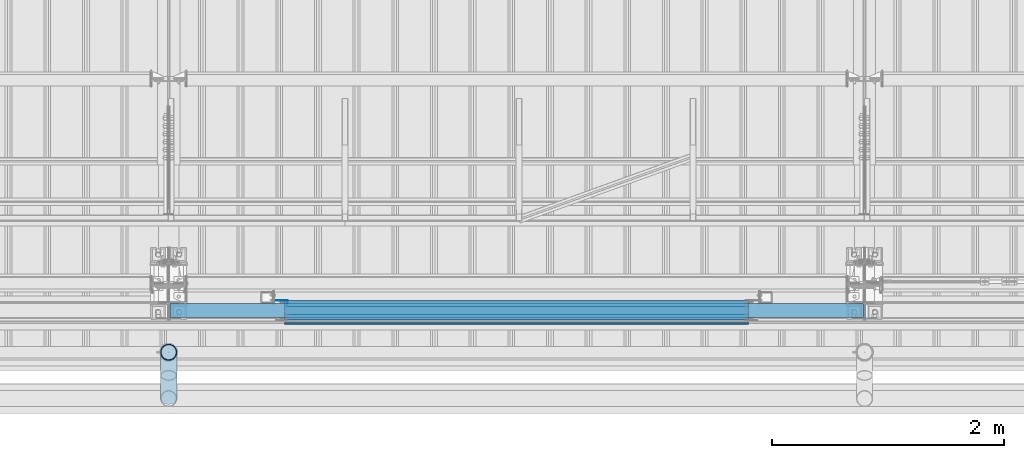
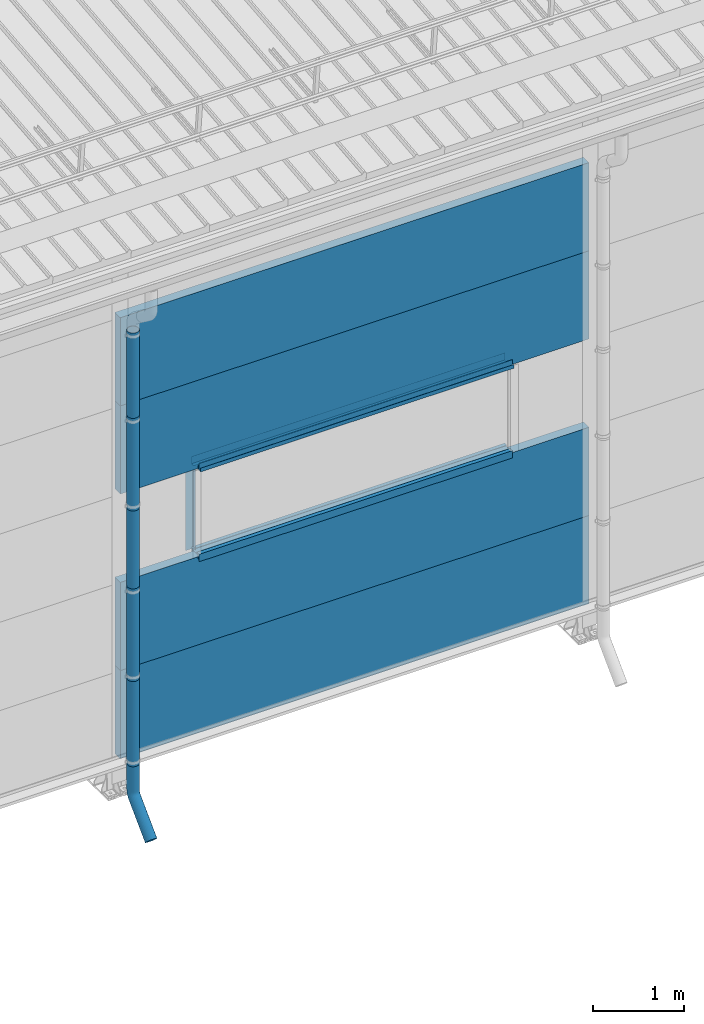
# One storey, part 41 of 709: 18 beams, 18 elements without a shape of their own.
"""IFC4 building model written with IfcOpenShell, lengths in millimetres."""

from ifc_helpers import new_model, entity, si_unit, direction, frame, origin_with_axes, place, context, subcontext, project, spatial, line, indexed_curve, outline, extrude, material, element, aggregate, save


model = new_model("IFC4")

# Units and contexts
model_context = context("Model", 3, precision=0.2, world=origin_with_axes(), true_north=direction((0.0, 1.0)))
body_context = subcontext(model_context, "Body", "Model", "MODEL_VIEW")
ifc_project = project(units=[si_unit("LENGTHUNIT", "METRE", prefix="MILLI"), si_unit("AREAUNIT", "SQUARE_METRE"), si_unit("VOLUMEUNIT", "CUBIC_METRE"), si_unit("MASSUNIT", "GRAM", prefix="KILO"), si_unit("TIMEUNIT", "SECOND"), si_unit("PLANEANGLEUNIT", "RADIAN"), si_unit("SOLIDANGLEUNIT", "STERADIAN"), si_unit("THERMODYNAMICTEMPERATUREUNIT", "DEGREE_CELSIUS"), si_unit("LUMINOUSINTENSITYUNIT", "LUMEN")], contexts=[model_context])

# Site, building, storey
site_placement = place(None, origin_with_axes())
site = spatial("IfcSite", under=ifc_project, at=site_placement, CompositionType="ELEMENT")
building_placement = place(site_placement, origin_with_axes())
building = spatial("IfcBuilding", under=site, at=building_placement, Name="Undefined", CompositionType="ELEMENT")
storey_placement = place(building_placement, origin_with_axes())
storey = spatial("IfcBuildingStorey", under=building, at=storey_placement, Name="Undefined", CompositionType="ELEMENT", Elevation=0.0)

# Assembly, beam
assembly_1_placement = place(storey_placement, frame((16010.0, -60.0, 895.0), z_axis=(0.0, 0.0, -1.0), x_axis=(1.0, 0.0, 0.0)))
assembly_1 = element("IfcElementAssembly", 1, at=assembly_1_placement, inside=storey)
ifc_material_1 = material(Name="Insulation", Category="Insulation")
beam_1_placement = place(assembly_1_placement, origin_with_axes())
beam_1 = element("IfcBeam", 2, at=beam_1_placement, material=ifc_material_1, ObjectType="P-107", context=body_context, shape_type="SolidModel", body=[
    extrude(outline(indexed_curve([(-595.0, -60.0), (595.0, -60.0), (595.0, 60.0), (-595.0, 60.0)], segments=[line(1, 2, 3, 4, 1)])), frame((0.0, 0.0, 0.0), z_axis=(-1.0, 0.0, 0.0), x_axis=(0.0, 0.0, 1.0)), (0.0, 0.0, -1.0), 5980.0),
])
aggregate(assembly_1, [beam_1])

assembly_2_placement = place(storey_placement, frame((16010.0, -60.0, 2085.0), z_axis=(0.0, 0.0, -1.0), x_axis=(1.0, 0.0, 0.0)))
assembly_2 = element("IfcElementAssembly", 3, at=assembly_2_placement, inside=storey)
beam_2_placement = place(assembly_2_placement, origin_with_axes())
beam_2 = element("IfcBeam", 4, at=beam_2_placement, material=ifc_material_1, ObjectType="P-107", context=body_context, shape_type="SolidModel", body=[
    extrude(outline(indexed_curve([(-595.0, -60.0), (595.0, -60.0), (595.0, 60.0), (-595.0, 60.0)], segments=[line(1, 2, 3, 4, 1)])), frame((0.0, 0.0, 0.0), z_axis=(-1.0, 0.0, 0.0), x_axis=(0.0, 0.0, 1.0)), (0.0, 0.0, -1.0), 5980.0),
])
aggregate(assembly_2, [beam_2])

assembly_3_placement = place(storey_placement, frame((16010.0, -60.0, 4465.0), z_axis=(0.0, 0.0, -1.0), x_axis=(1.0, 0.0, 0.0)))
assembly_3 = element("IfcElementAssembly", 5, at=assembly_3_placement, inside=storey)
beam_3_placement = place(assembly_3_placement, origin_with_axes())
beam_3 = element("IfcBeam", 6, at=beam_3_placement, material=ifc_material_1, ObjectType="P-107", context=body_context, shape_type="SolidModel", body=[
    extrude(outline(indexed_curve([(-595.0, -60.0), (595.0, -60.0), (595.0, 60.0), (-595.0, 60.0)], segments=[line(1, 2, 3, 4, 1)])), frame((0.0, 0.0, 0.0), z_axis=(-1.0, 0.0, 0.0), x_axis=(0.0, 0.0, 1.0)), (0.0, 0.0, -1.0), 5980.0),
])
aggregate(assembly_3, [beam_3])

assembly_4_placement = place(storey_placement, frame((16010.0, -60.0, 5655.0), z_axis=(0.0, 0.0, -1.0), x_axis=(1.0, 0.0, 0.0)))
assembly_4 = element("IfcElementAssembly", 7, at=assembly_4_placement, inside=storey)
beam_4_placement = place(assembly_4_placement, origin_with_axes())
beam_4 = element("IfcBeam", 8, at=beam_4_placement, material=ifc_material_1, ObjectType="P-107", context=body_context, shape_type="SolidModel", body=[
    extrude(outline(indexed_curve([(-595.0, -60.0), (595.0, -60.0), (595.0, 60.0), (-595.0, 60.0)], segments=[line(1, 2, 3, 4, 1)])), frame((0.0, 0.0, 0.0), z_axis=(-1.0, 0.0, 0.0), x_axis=(0.0, 0.0, 1.0)), (0.0, 0.0, -1.0), 5980.0),
])
aggregate(assembly_4, [beam_4])

assembly_5_placement = place(storey_placement, frame((17000.0, 1.0, 2725.0), z_axis=(0.0, 1.0, 0.0), x_axis=(1.0, 0.0, 0.0)))
assembly_5 = element("IfcElementAssembly", 9, at=assembly_5_placement, inside=storey)
ifc_material_2 = material(Name="Steel_Undefined", Category="STEEL")
beam_5_placement = place(assembly_5_placement, origin_with_axes())
beam_5 = element("IfcBeam", 10, at=beam_5_placement, material=ifc_material_2, context=body_context, shape_type="SolidModel", body=[
    extrude(outline(indexed_curve([(-25.0, -1.0), (25.0, -1.0), (25.0, 99.0), (23.0, 99.0), (23.0, 1.0), (-25.0, 1.0)], segments=[line(1, 2, 3, 4, 5, 6, 1)])), frame((0.0, 0.0, 0.0), z_axis=(-1.0, 0.0, 0.0), x_axis=(0.0, 0.0, 1.0)), (0.0, 0.0, -1.0), 4000.0),
])
aggregate(assembly_5, [beam_5])

assembly_6_placement = place(storey_placement, frame((21000.0, -60.0, 2680.0), z_axis=(0.0, 1.0, 0.0), x_axis=(-1.0, 0.0, 0.0)))
assembly_6 = element("IfcElementAssembly", 11, at=assembly_6_placement, inside=storey)
beam_6_placement = place(assembly_6_placement, origin_with_axes())
beam_6 = element("IfcBeam", 12, at=beam_6_placement, material=ifc_material_2, context=body_context, shape_type="SolidModel", body=[
    extrude(outline(indexed_curve([(-70.0, -25.0), (-68.0, -25.0), (-68.0, 23.0), (68.0, 23.0), (68.0, -25.0), (70.0, -25.0), (70.0, 25.0), (-70.0, 25.0)], segments=[line(1, 2, 3, 4, 5, 6, 7, 8, 1)])), frame((0.0, 0.0, 0.0), z_axis=(-1.0, 0.0, 0.0), x_axis=(0.0, 0.0, 1.0)), (0.0, 0.0, -1.0), 4000.0),
])
aggregate(assembly_6, [beam_6])

assembly_7_placement = place(storey_placement, frame((21000.0, -119.0, 2725.0), z_axis=(0.0, -1.0, 0.0), x_axis=(-1.0, 0.0, 0.0)))
assembly_7 = element("IfcElementAssembly", 13, at=assembly_7_placement, inside=storey)
beam_7_placement = place(assembly_7_placement, origin_with_axes())
beam_7 = element("IfcBeam", 14, at=beam_7_placement, material=ifc_material_2, context=body_context, shape_type="SolidModel", body=[
    extrude(outline(indexed_curve([(-25.0, -1.0), (25.0, -1.0), (25.0, 99.0), (23.0, 99.0), (23.0, 1.0), (-25.0, 1.0)], segments=[line(1, 2, 3, 4, 5, 6, 1)])), frame((0.0, 0.0, 0.0), z_axis=(-1.0, 0.0, 0.0), x_axis=(0.0, 0.0, 1.0)), (0.0, 0.0, -1.0), 4000.0),
])
aggregate(assembly_7, [beam_7])

assembly_8_placement = place(storey_placement, frame((21000.0, 1.0, 3845.0), z_axis=(0.0, 1.0, 0.0), x_axis=(-1.0, 0.0, 0.0)))
assembly_8 = element("IfcElementAssembly", 15, at=assembly_8_placement, inside=storey)
beam_8_placement = place(assembly_8_placement, origin_with_axes())
beam_8 = element("IfcBeam", 16, at=beam_8_placement, material=ifc_material_2, context=body_context, shape_type="SolidModel", body=[
    extrude(outline(indexed_curve([(-25.0, -1.0), (25.0, -1.0), (25.0, 99.0), (23.0, 99.0), (23.0, 1.0), (-25.0, 1.0)], segments=[line(1, 2, 3, 4, 5, 6, 1)])), frame((0.0, 0.0, 0.0), z_axis=(-1.0, 0.0, 0.0), x_axis=(0.0, 0.0, 1.0)), (0.0, 0.0, -1.0), 4000.0),
])
aggregate(assembly_8, [beam_8])

assembly_9_placement = place(storey_placement, frame((17000.0, -60.0, 3890.0), z_axis=(0.0, 1.0, 0.0), x_axis=(1.0, 0.0, 0.0)))
assembly_9 = element("IfcElementAssembly", 17, at=assembly_9_placement, inside=storey)
beam_9_placement = place(assembly_9_placement, origin_with_axes())
beam_9 = element("IfcBeam", 18, at=beam_9_placement, material=ifc_material_2, context=body_context, shape_type="SolidModel", body=[
    extrude(outline(indexed_curve([(-70.0, -25.0), (-68.0, -25.0), (-68.0, 23.0), (68.0, 23.0), (68.0, -25.0), (70.0, -25.0), (70.0, 25.0), (-70.0, 25.0)], segments=[line(1, 2, 3, 4, 5, 6, 7, 8, 1)])), frame((0.0, 0.0, 0.0), z_axis=(-1.0, 0.0, 0.0), x_axis=(0.0, 0.0, 1.0)), (0.0, 0.0, -1.0), 4000.0),
])
aggregate(assembly_9, [beam_9])

assembly_10_placement = place(storey_placement, frame((17000.0, -119.0, 3855.0), z_axis=(0.0, -1.0, 0.0), x_axis=(1.0, 0.0, 0.0)))
assembly_10 = element("IfcElementAssembly", 19, at=assembly_10_placement, inside=storey)
beam_10_placement = place(assembly_10_placement, origin_with_axes())
beam_10 = element("IfcBeam", 20, at=beam_10_placement, material=ifc_material_2, context=body_context, shape_type="SolidModel", body=[
    extrude(outline(indexed_curve([(-25.0, -1.0), (25.0, -1.0), (25.0, 99.0), (23.0, 99.0), (23.0, 1.0), (-25.0, 1.0)], segments=[line(1, 2, 3, 4, 5, 6, 1)])), frame((0.0, 0.0, 0.0), z_axis=(-1.0, 0.0, 0.0), x_axis=(0.0, 0.0, 1.0)), (0.0, 0.0, -1.0), 4000.0),
])
aggregate(assembly_10, [beam_10])

assembly_11_placement = place(storey_placement, frame((17000.0, -169.0, 3860.0), z_axis=(0.0, -1.0, 0.0), x_axis=(1.0, 0.0, 0.0)))
assembly_11 = element("IfcElementAssembly", 21, at=assembly_11_placement, inside=storey)
beam_11_placement = place(assembly_11_placement, origin_with_axes())
beam_11 = element("IfcBeam", 22, at=beam_11_placement, material=ifc_material_2, context=body_context, shape_type="SolidModel", body=[
    extrude(outline(indexed_curve([(-10.0, -1.0), (10.0, -1.0), (10.0, 49.0), (8.0, 49.0), (8.0, 1.0), (-10.0, 1.0)], segments=[line(1, 2, 3, 4, 5, 6, 1)])), frame((0.0, 0.0, 0.0), z_axis=(-1.0, 0.0, 0.0), x_axis=(0.0, 0.0, 1.0)), (0.0, 0.0, -1.0), 4000.0),
])
aggregate(assembly_11, [beam_11])

assembly_12_placement = place(storey_placement, frame((17025.0, 1.0, 3870.0), z_axis=(0.0, 1.0, 0.0), x_axis=(0.0, 0.0, -1.0)))
assembly_12 = element("IfcElementAssembly", 23, at=assembly_12_placement, inside=storey)
beam_12_placement = place(assembly_12_placement, origin_with_axes())
beam_12 = element("IfcBeam", 24, at=beam_12_placement, material=ifc_material_2, context=body_context, shape_type="SolidModel", body=[
    extrude(outline(indexed_curve([(-25.0, -1.0), (25.0, -1.0), (25.0, 99.0), (23.0, 99.0), (23.0, 1.0), (-25.0, 1.0)], segments=[line(1, 2, 3, 4, 5, 6, 1)])), frame((0.0, 0.0, 0.0), z_axis=(-1.0, 0.0, 0.0), x_axis=(0.0, 0.0, 1.0)), (0.0, 0.0, -1.0), 1170.0),
])
aggregate(assembly_12, [beam_12])

assembly_13_placement = place(storey_placement, frame((16000.0, -420.0, 6276.92297), z_axis=(0.0, 1.0, 0.0), x_axis=(0.0, 0.0, -1.0)))
assembly_13 = element("IfcElementAssembly", 25, at=assembly_13_placement, inside=storey)
beam_13_placement = place(assembly_13_placement, origin_with_axes())
beam_13 = element("IfcBeam", 26, at=beam_13_placement, material=ifc_material_2, ObjectType="614", context=body_context, shape_type="SolidModel", body=[
    extrude(outline(indexed_curve([(70.0, 0.0), (69.61653, 7.31699), (68.47033, 14.55382), (66.57396, 21.63119), (63.94818, 28.47157), (60.62178, 35.0), (56.63119, 41.14497), (52.02014, 46.83914), (46.83914, 52.02014), (41.14497, 56.63119), (35.0, 60.62178), (28.47157, 63.94818), (21.63119, 66.57396), (14.55382, 68.47033), (7.31699, 69.61653), (0.0, 70.0), (-7.31699, 69.61653), (-14.55382, 68.47033), (-21.63119, 66.57396), (-28.47157, 63.94818), (-35.0, 60.62178), (-41.14497, 56.63119), (-46.83914, 52.02014), (-52.02014, 46.83914), (-56.63119, 41.14497), (-60.62178, 35.0), (-63.94818, 28.47157), (-66.57396, 21.63119), (-68.47033, 14.55382), (-69.61653, 7.31699), (-70.0, 0.0), (-69.61653, -7.31699), (-68.47033, -14.55382), (-66.57396, -21.63119), (-63.94818, -28.47157), (-60.62178, -35.0), (-56.63119, -41.14497), (-52.02014, -46.83914), (-46.83914, -52.02014), (-41.14497, -56.63119), (-35.0, -60.62178), (-28.47157, -63.94818), (-21.63119, -66.57396), (-14.55382, -68.47033), (-7.31699, -69.61653), (0.0, -70.0), (7.31699, -69.61653), (14.55382, -68.47033), (21.63119, -66.57396), (28.47157, -63.94818), (35.0, -60.62178), (41.14497, -56.63119), (46.83914, -52.02014), (52.02014, -46.83914), (56.63119, -41.14497), (60.62178, -35.0), (63.94818, -28.47157), (66.57396, -21.63119), (68.47033, -14.55382), (69.61653, -7.31699)], segments=[line(1, 2, 3, 4, 5, 6, 7, 8, 9, 10, 11, 12, 13, 14, 15, 16, 17, 18, 19, 20, 21, 22, 23, 24, 25, 26, 27, 28, 29, 30, 31, 32, 33, 34, 35, 36, 37, 38, 39, 40, 41, 42, 43, 44, 45, 46, 47, 48, 49, 50, 51, 52, 53, 54, 55, 56, 57, 58, 59, 60, 1)]), holes=[indexed_curve([(65.0, 0.0), (64.64392, -6.79435), (63.57959, -13.51426), (61.81867, -20.0861), (59.38045, -26.43788), (56.29165, -32.5), (52.5861, -38.20604), (48.30441, -43.49349), (43.49349, -48.30441), (38.20604, -52.5861), (32.5, -56.29165), (26.43788, -59.38045), (20.0861, -61.81867), (13.51426, -63.57959), (6.79435, -64.64392), (0.0, -65.0), (-6.79435, -64.64392), (-13.51426, -63.57959), (-20.0861, -61.81867), (-26.43788, -59.38045), (-32.5, -56.29165), (-38.20604, -52.5861), (-43.49349, -48.30441), (-48.30441, -43.49349), (-52.5861, -38.20604), (-56.29165, -32.5), (-59.38045, -26.43788), (-61.81867, -20.0861), (-63.57959, -13.51426), (-64.64392, -6.79435), (-65.0, 0.0), (-64.64392, 6.79435), (-63.57959, 13.51426), (-61.81867, 20.0861), (-59.38045, 26.43788), (-56.29165, 32.5), (-52.5861, 38.20604), (-48.30441, 43.49349), (-43.49349, 48.30441), (-38.20604, 52.5861), (-32.5, 56.29165), (-26.43788, 59.38045), (-20.0861, 61.81867), (-13.51426, 63.57959), (-6.79435, 64.64392), (0.0, 65.0), (6.79435, 64.64392), (13.51426, 63.57959), (20.0861, 61.81867), (26.43788, 59.38045), (32.5, 56.29165), (38.20604, 52.5861), (43.49349, 48.30441), (48.30441, 43.49349), (52.5861, 38.20604), (56.29165, 32.5), (59.38045, 26.43788), (61.81867, 20.0861), (63.57959, 13.51426), (64.64392, 6.79435)], segments=[line(1, 2, 3, 4, 5, 6, 7, 8, 9, 10, 11, 12, 13, 14, 15, 16, 17, 18, 19, 20, 21, 22, 23, 24, 25, 26, 27, 28, 29, 30, 31, 32, 33, 34, 35, 36, 37, 38, 39, 40, 41, 42, 43, 44, 45, 46, 47, 48, 49, 50, 51, 52, 53, 54, 55, 56, 57, 58, 59, 60, 1)])]), frame((0.0, 0.0, 0.0), z_axis=(-1.0, 0.0, 0.0), x_axis=(0.0, 0.0, 1.0)), (0.0, 0.0, -1.0), 1250.0),
])
aggregate(assembly_13, [beam_13])

assembly_14_placement = place(storey_placement, frame((16000.0, -420.0, 5126.92297), z_axis=(0.0, 1.0, 0.0), x_axis=(0.0, 0.0, -1.0)))
assembly_14 = element("IfcElementAssembly", 27, at=assembly_14_placement, inside=storey)
beam_14_placement = place(assembly_14_placement, origin_with_axes())
beam_14 = element("IfcBeam", 28, at=beam_14_placement, material=ifc_material_2, ObjectType="614", context=body_context, shape_type="SolidModel", body=[
    extrude(outline(indexed_curve([(70.0, 0.0), (69.61653, 7.31699), (68.47033, 14.55382), (66.57396, 21.63119), (63.94818, 28.47157), (60.62178, 35.0), (56.63119, 41.14497), (52.02014, 46.83914), (46.83914, 52.02014), (41.14497, 56.63119), (35.0, 60.62178), (28.47157, 63.94818), (21.63119, 66.57396), (14.55382, 68.47033), (7.31699, 69.61653), (0.0, 70.0), (-7.31699, 69.61653), (-14.55382, 68.47033), (-21.63119, 66.57396), (-28.47157, 63.94818), (-35.0, 60.62178), (-41.14497, 56.63119), (-46.83914, 52.02014), (-52.02014, 46.83914), (-56.63119, 41.14497), (-60.62178, 35.0), (-63.94818, 28.47157), (-66.57396, 21.63119), (-68.47033, 14.55382), (-69.61653, 7.31699), (-70.0, 0.0), (-69.61653, -7.31699), (-68.47033, -14.55382), (-66.57396, -21.63119), (-63.94818, -28.47157), (-60.62178, -35.0), (-56.63119, -41.14497), (-52.02014, -46.83914), (-46.83914, -52.02014), (-41.14497, -56.63119), (-35.0, -60.62178), (-28.47157, -63.94818), (-21.63119, -66.57396), (-14.55382, -68.47033), (-7.31699, -69.61653), (0.0, -70.0), (7.31699, -69.61653), (14.55382, -68.47033), (21.63119, -66.57396), (28.47157, -63.94818), (35.0, -60.62178), (41.14497, -56.63119), (46.83914, -52.02014), (52.02014, -46.83914), (56.63119, -41.14497), (60.62178, -35.0), (63.94818, -28.47157), (66.57396, -21.63119), (68.47033, -14.55382), (69.61653, -7.31699)], segments=[line(1, 2, 3, 4, 5, 6, 7, 8, 9, 10, 11, 12, 13, 14, 15, 16, 17, 18, 19, 20, 21, 22, 23, 24, 25, 26, 27, 28, 29, 30, 31, 32, 33, 34, 35, 36, 37, 38, 39, 40, 41, 42, 43, 44, 45, 46, 47, 48, 49, 50, 51, 52, 53, 54, 55, 56, 57, 58, 59, 60, 1)]), holes=[indexed_curve([(65.0, 0.0), (64.64392, -6.79435), (63.57959, -13.51426), (61.81867, -20.0861), (59.38045, -26.43788), (56.29165, -32.5), (52.5861, -38.20604), (48.30441, -43.49349), (43.49349, -48.30441), (38.20604, -52.5861), (32.5, -56.29165), (26.43788, -59.38045), (20.0861, -61.81867), (13.51426, -63.57959), (6.79435, -64.64392), (0.0, -65.0), (-6.79435, -64.64392), (-13.51426, -63.57959), (-20.0861, -61.81867), (-26.43788, -59.38045), (-32.5, -56.29165), (-38.20604, -52.5861), (-43.49349, -48.30441), (-48.30441, -43.49349), (-52.5861, -38.20604), (-56.29165, -32.5), (-59.38045, -26.43788), (-61.81867, -20.0861), (-63.57959, -13.51426), (-64.64392, -6.79435), (-65.0, 0.0), (-64.64392, 6.79435), (-63.57959, 13.51426), (-61.81867, 20.0861), (-59.38045, 26.43788), (-56.29165, 32.5), (-52.5861, 38.20604), (-48.30441, 43.49349), (-43.49349, 48.30441), (-38.20604, 52.5861), (-32.5, 56.29165), (-26.43788, 59.38045), (-20.0861, 61.81867), (-13.51426, 63.57959), (-6.79435, 64.64392), (0.0, 65.0), (6.79435, 64.64392), (13.51426, 63.57959), (20.0861, 61.81867), (26.43788, 59.38045), (32.5, 56.29165), (38.20604, 52.5861), (43.49349, 48.30441), (48.30441, 43.49349), (52.5861, 38.20604), (56.29165, 32.5), (59.38045, 26.43788), (61.81867, 20.0861), (63.57959, 13.51426), (64.64392, 6.79435)], segments=[line(1, 2, 3, 4, 5, 6, 7, 8, 9, 10, 11, 12, 13, 14, 15, 16, 17, 18, 19, 20, 21, 22, 23, 24, 25, 26, 27, 28, 29, 30, 31, 32, 33, 34, 35, 36, 37, 38, 39, 40, 41, 42, 43, 44, 45, 46, 47, 48, 49, 50, 51, 52, 53, 54, 55, 56, 57, 58, 59, 60, 1)])]), frame((0.0, 0.0, 0.0), z_axis=(-1.0, 0.0, 0.0), x_axis=(0.0, 0.0, 1.0)), (0.0, 0.0, -1.0), 1250.0),
])
aggregate(assembly_14, [beam_14])

assembly_15_placement = place(storey_placement, frame((16000.0, -420.0, 3976.92297), z_axis=(0.0, 1.0, 0.0), x_axis=(0.0, 0.0, -1.0)))
assembly_15 = element("IfcElementAssembly", 29, at=assembly_15_placement, inside=storey)
beam_15_placement = place(assembly_15_placement, origin_with_axes())
beam_15 = element("IfcBeam", 30, at=beam_15_placement, material=ifc_material_2, ObjectType="614", context=body_context, shape_type="SolidModel", body=[
    extrude(outline(indexed_curve([(70.0, 0.0), (69.61653, 7.31699), (68.47033, 14.55382), (66.57396, 21.63119), (63.94818, 28.47157), (60.62178, 35.0), (56.63119, 41.14497), (52.02014, 46.83914), (46.83914, 52.02014), (41.14497, 56.63119), (35.0, 60.62178), (28.47157, 63.94818), (21.63119, 66.57396), (14.55382, 68.47033), (7.31699, 69.61653), (0.0, 70.0), (-7.31699, 69.61653), (-14.55382, 68.47033), (-21.63119, 66.57396), (-28.47157, 63.94818), (-35.0, 60.62178), (-41.14497, 56.63119), (-46.83914, 52.02014), (-52.02014, 46.83914), (-56.63119, 41.14497), (-60.62178, 35.0), (-63.94818, 28.47157), (-66.57396, 21.63119), (-68.47033, 14.55382), (-69.61653, 7.31699), (-70.0, 0.0), (-69.61653, -7.31699), (-68.47033, -14.55382), (-66.57396, -21.63119), (-63.94818, -28.47157), (-60.62178, -35.0), (-56.63119, -41.14497), (-52.02014, -46.83914), (-46.83914, -52.02014), (-41.14497, -56.63119), (-35.0, -60.62178), (-28.47157, -63.94818), (-21.63119, -66.57396), (-14.55382, -68.47033), (-7.31699, -69.61653), (0.0, -70.0), (7.31699, -69.61653), (14.55382, -68.47033), (21.63119, -66.57396), (28.47157, -63.94818), (35.0, -60.62178), (41.14497, -56.63119), (46.83914, -52.02014), (52.02014, -46.83914), (56.63119, -41.14497), (60.62178, -35.0), (63.94818, -28.47157), (66.57396, -21.63119), (68.47033, -14.55382), (69.61653, -7.31699)], segments=[line(1, 2, 3, 4, 5, 6, 7, 8, 9, 10, 11, 12, 13, 14, 15, 16, 17, 18, 19, 20, 21, 22, 23, 24, 25, 26, 27, 28, 29, 30, 31, 32, 33, 34, 35, 36, 37, 38, 39, 40, 41, 42, 43, 44, 45, 46, 47, 48, 49, 50, 51, 52, 53, 54, 55, 56, 57, 58, 59, 60, 1)]), holes=[indexed_curve([(65.0, 0.0), (64.64392, -6.79435), (63.57959, -13.51426), (61.81867, -20.0861), (59.38045, -26.43788), (56.29165, -32.5), (52.5861, -38.20604), (48.30441, -43.49349), (43.49349, -48.30441), (38.20604, -52.5861), (32.5, -56.29165), (26.43788, -59.38045), (20.0861, -61.81867), (13.51426, -63.57959), (6.79435, -64.64392), (0.0, -65.0), (-6.79435, -64.64392), (-13.51426, -63.57959), (-20.0861, -61.81867), (-26.43788, -59.38045), (-32.5, -56.29165), (-38.20604, -52.5861), (-43.49349, -48.30441), (-48.30441, -43.49349), (-52.5861, -38.20604), (-56.29165, -32.5), (-59.38045, -26.43788), (-61.81867, -20.0861), (-63.57959, -13.51426), (-64.64392, -6.79435), (-65.0, 0.0), (-64.64392, 6.79435), (-63.57959, 13.51426), (-61.81867, 20.0861), (-59.38045, 26.43788), (-56.29165, 32.5), (-52.5861, 38.20604), (-48.30441, 43.49349), (-43.49349, 48.30441), (-38.20604, 52.5861), (-32.5, 56.29165), (-26.43788, 59.38045), (-20.0861, 61.81867), (-13.51426, 63.57959), (-6.79435, 64.64392), (0.0, 65.0), (6.79435, 64.64392), (13.51426, 63.57959), (20.0861, 61.81867), (26.43788, 59.38045), (32.5, 56.29165), (38.20604, 52.5861), (43.49349, 48.30441), (48.30441, 43.49349), (52.5861, 38.20604), (56.29165, 32.5), (59.38045, 26.43788), (61.81867, 20.0861), (63.57959, 13.51426), (64.64392, 6.79435)], segments=[line(1, 2, 3, 4, 5, 6, 7, 8, 9, 10, 11, 12, 13, 14, 15, 16, 17, 18, 19, 20, 21, 22, 23, 24, 25, 26, 27, 28, 29, 30, 31, 32, 33, 34, 35, 36, 37, 38, 39, 40, 41, 42, 43, 44, 45, 46, 47, 48, 49, 50, 51, 52, 53, 54, 55, 56, 57, 58, 59, 60, 1)])]), frame((0.0, 0.0, 0.0), z_axis=(-1.0, 0.0, 0.0), x_axis=(0.0, 0.0, 1.0)), (0.0, 0.0, -1.0), 1250.0),
])
aggregate(assembly_15, [beam_15])

assembly_16_placement = place(storey_placement, frame((16000.0, -420.0, 2826.92297), z_axis=(0.0, 1.0, 0.0), x_axis=(0.0, 0.0, -1.0)))
assembly_16 = element("IfcElementAssembly", 31, at=assembly_16_placement, inside=storey)
beam_16_placement = place(assembly_16_placement, origin_with_axes())
beam_16 = element("IfcBeam", 32, at=beam_16_placement, material=ifc_material_2, ObjectType="614", context=body_context, shape_type="SolidModel", body=[
    extrude(outline(indexed_curve([(70.0, 0.0), (69.61653, 7.31699), (68.47033, 14.55382), (66.57396, 21.63119), (63.94818, 28.47157), (60.62178, 35.0), (56.63119, 41.14497), (52.02014, 46.83914), (46.83914, 52.02014), (41.14497, 56.63119), (35.0, 60.62178), (28.47157, 63.94818), (21.63119, 66.57396), (14.55382, 68.47033), (7.31699, 69.61653), (0.0, 70.0), (-7.31699, 69.61653), (-14.55382, 68.47033), (-21.63119, 66.57396), (-28.47157, 63.94818), (-35.0, 60.62178), (-41.14497, 56.63119), (-46.83914, 52.02014), (-52.02014, 46.83914), (-56.63119, 41.14497), (-60.62178, 35.0), (-63.94818, 28.47157), (-66.57396, 21.63119), (-68.47033, 14.55382), (-69.61653, 7.31699), (-70.0, 0.0), (-69.61653, -7.31699), (-68.47033, -14.55382), (-66.57396, -21.63119), (-63.94818, -28.47157), (-60.62178, -35.0), (-56.63119, -41.14497), (-52.02014, -46.83914), (-46.83914, -52.02014), (-41.14497, -56.63119), (-35.0, -60.62178), (-28.47157, -63.94818), (-21.63119, -66.57396), (-14.55382, -68.47033), (-7.31699, -69.61653), (0.0, -70.0), (7.31699, -69.61653), (14.55382, -68.47033), (21.63119, -66.57396), (28.47157, -63.94818), (35.0, -60.62178), (41.14497, -56.63119), (46.83914, -52.02014), (52.02014, -46.83914), (56.63119, -41.14497), (60.62178, -35.0), (63.94818, -28.47157), (66.57396, -21.63119), (68.47033, -14.55382), (69.61653, -7.31699)], segments=[line(1, 2, 3, 4, 5, 6, 7, 8, 9, 10, 11, 12, 13, 14, 15, 16, 17, 18, 19, 20, 21, 22, 23, 24, 25, 26, 27, 28, 29, 30, 31, 32, 33, 34, 35, 36, 37, 38, 39, 40, 41, 42, 43, 44, 45, 46, 47, 48, 49, 50, 51, 52, 53, 54, 55, 56, 57, 58, 59, 60, 1)]), holes=[indexed_curve([(65.0, 0.0), (64.64392, -6.79435), (63.57959, -13.51426), (61.81867, -20.0861), (59.38045, -26.43788), (56.29165, -32.5), (52.5861, -38.20604), (48.30441, -43.49349), (43.49349, -48.30441), (38.20604, -52.5861), (32.5, -56.29165), (26.43788, -59.38045), (20.0861, -61.81867), (13.51426, -63.57959), (6.79435, -64.64392), (0.0, -65.0), (-6.79435, -64.64392), (-13.51426, -63.57959), (-20.0861, -61.81867), (-26.43788, -59.38045), (-32.5, -56.29165), (-38.20604, -52.5861), (-43.49349, -48.30441), (-48.30441, -43.49349), (-52.5861, -38.20604), (-56.29165, -32.5), (-59.38045, -26.43788), (-61.81867, -20.0861), (-63.57959, -13.51426), (-64.64392, -6.79435), (-65.0, 0.0), (-64.64392, 6.79435), (-63.57959, 13.51426), (-61.81867, 20.0861), (-59.38045, 26.43788), (-56.29165, 32.5), (-52.5861, 38.20604), (-48.30441, 43.49349), (-43.49349, 48.30441), (-38.20604, 52.5861), (-32.5, 56.29165), (-26.43788, 59.38045), (-20.0861, 61.81867), (-13.51426, 63.57959), (-6.79435, 64.64392), (0.0, 65.0), (6.79435, 64.64392), (13.51426, 63.57959), (20.0861, 61.81867), (26.43788, 59.38045), (32.5, 56.29165), (38.20604, 52.5861), (43.49349, 48.30441), (48.30441, 43.49349), (52.5861, 38.20604), (56.29165, 32.5), (59.38045, 26.43788), (61.81867, 20.0861), (63.57959, 13.51426), (64.64392, 6.79435)], segments=[line(1, 2, 3, 4, 5, 6, 7, 8, 9, 10, 11, 12, 13, 14, 15, 16, 17, 18, 19, 20, 21, 22, 23, 24, 25, 26, 27, 28, 29, 30, 31, 32, 33, 34, 35, 36, 37, 38, 39, 40, 41, 42, 43, 44, 45, 46, 47, 48, 49, 50, 51, 52, 53, 54, 55, 56, 57, 58, 59, 60, 1)])]), frame((0.0, 0.0, 0.0), z_axis=(-1.0, 0.0, 0.0), x_axis=(0.0, 0.0, 1.0)), (0.0, 0.0, -1.0), 1250.0),
])
aggregate(assembly_16, [beam_16])

assembly_17_placement = place(storey_placement, frame((16000.0, -420.0, 1676.92297), z_axis=(0.0, 1.0, 0.0), x_axis=(0.0, 0.0, -1.0)))
assembly_17 = element("IfcElementAssembly", 33, at=assembly_17_placement, inside=storey)
beam_17_placement = place(assembly_17_placement, origin_with_axes())
beam_17 = element("IfcBeam", 34, at=beam_17_placement, material=ifc_material_2, ObjectType="614", context=body_context, shape_type="SolidModel", body=[
    extrude(outline(indexed_curve([(70.0, 0.0), (69.61653, 7.31699), (68.47033, 14.55382), (66.57396, 21.63119), (63.94818, 28.47157), (60.62178, 35.0), (56.63119, 41.14497), (52.02014, 46.83914), (46.83914, 52.02014), (41.14497, 56.63119), (35.0, 60.62178), (28.47157, 63.94818), (21.63119, 66.57396), (14.55382, 68.47033), (7.31699, 69.61653), (0.0, 70.0), (-7.31699, 69.61653), (-14.55382, 68.47033), (-21.63119, 66.57396), (-28.47157, 63.94818), (-35.0, 60.62178), (-41.14497, 56.63119), (-46.83914, 52.02014), (-52.02014, 46.83914), (-56.63119, 41.14497), (-60.62178, 35.0), (-63.94818, 28.47157), (-66.57396, 21.63119), (-68.47033, 14.55382), (-69.61653, 7.31699), (-70.0, 0.0), (-69.61653, -7.31699), (-68.47033, -14.55382), (-66.57396, -21.63119), (-63.94818, -28.47157), (-60.62178, -35.0), (-56.63119, -41.14497), (-52.02014, -46.83914), (-46.83914, -52.02014), (-41.14497, -56.63119), (-35.0, -60.62178), (-28.47157, -63.94818), (-21.63119, -66.57396), (-14.55382, -68.47033), (-7.31699, -69.61653), (0.0, -70.0), (7.31699, -69.61653), (14.55382, -68.47033), (21.63119, -66.57396), (28.47157, -63.94818), (35.0, -60.62178), (41.14497, -56.63119), (46.83914, -52.02014), (52.02014, -46.83914), (56.63119, -41.14497), (60.62178, -35.0), (63.94818, -28.47157), (66.57396, -21.63119), (68.47033, -14.55382), (69.61653, -7.31699)], segments=[line(1, 2, 3, 4, 5, 6, 7, 8, 9, 10, 11, 12, 13, 14, 15, 16, 17, 18, 19, 20, 21, 22, 23, 24, 25, 26, 27, 28, 29, 30, 31, 32, 33, 34, 35, 36, 37, 38, 39, 40, 41, 42, 43, 44, 45, 46, 47, 48, 49, 50, 51, 52, 53, 54, 55, 56, 57, 58, 59, 60, 1)]), holes=[indexed_curve([(65.0, 0.0), (64.64392, -6.79435), (63.57959, -13.51426), (61.81867, -20.0861), (59.38045, -26.43788), (56.29165, -32.5), (52.5861, -38.20604), (48.30441, -43.49349), (43.49349, -48.30441), (38.20604, -52.5861), (32.5, -56.29165), (26.43788, -59.38045), (20.0861, -61.81867), (13.51426, -63.57959), (6.79435, -64.64392), (0.0, -65.0), (-6.79435, -64.64392), (-13.51426, -63.57959), (-20.0861, -61.81867), (-26.43788, -59.38045), (-32.5, -56.29165), (-38.20604, -52.5861), (-43.49349, -48.30441), (-48.30441, -43.49349), (-52.5861, -38.20604), (-56.29165, -32.5), (-59.38045, -26.43788), (-61.81867, -20.0861), (-63.57959, -13.51426), (-64.64392, -6.79435), (-65.0, 0.0), (-64.64392, 6.79435), (-63.57959, 13.51426), (-61.81867, 20.0861), (-59.38045, 26.43788), (-56.29165, 32.5), (-52.5861, 38.20604), (-48.30441, 43.49349), (-43.49349, 48.30441), (-38.20604, 52.5861), (-32.5, 56.29165), (-26.43788, 59.38045), (-20.0861, 61.81867), (-13.51426, 63.57959), (-6.79435, 64.64392), (0.0, 65.0), (6.79435, 64.64392), (13.51426, 63.57959), (20.0861, 61.81867), (26.43788, 59.38045), (32.5, 56.29165), (38.20604, 52.5861), (43.49349, 48.30441), (48.30441, 43.49349), (52.5861, 38.20604), (56.29165, 32.5), (59.38045, 26.43788), (61.81867, 20.0861), (63.57959, 13.51426), (64.64392, 6.79435)], segments=[line(1, 2, 3, 4, 5, 6, 7, 8, 9, 10, 11, 12, 13, 14, 15, 16, 17, 18, 19, 20, 21, 22, 23, 24, 25, 26, 27, 28, 29, 30, 31, 32, 33, 34, 35, 36, 37, 38, 39, 40, 41, 42, 43, 44, 45, 46, 47, 48, 49, 50, 51, 52, 53, 54, 55, 56, 57, 58, 59, 60, 1)])]), frame((0.0, 0.0, 0.0), z_axis=(-1.0, 0.0, 0.0), x_axis=(0.0, 0.0, 1.0)), (0.0, 0.0, -1.0), 1250.0),
])
aggregate(assembly_17, [beam_17])

assembly_18_placement = place(storey_placement, frame((16000.0, -420.0, 526.92297), z_axis=(-1.0, 0.0, 0.0), x_axis=(0.0, 0.0, -1.0)))
assembly_18 = element("IfcElementAssembly", 35, at=assembly_18_placement, inside=storey)
beam_18_placement = place(assembly_18_placement, origin_with_axes())
beam_18 = element("IfcBeam", 36, at=beam_18_placement, material=ifc_material_2, ObjectType="617", context=body_context, shape_type="SolidModel", body=[
    entity("IfcSweptDiskSolid", entity("IfcIndexedPolyCurve", entity("IfcCartesianPointList3D", [[0.0, 0.0, 0.0], [448.2233, 0.0, 0.0], [496.05873, 9.51506, 0.0], [536.61165, 36.61165, 0.0], [900.0, 400.0, 0.0]]), [entity("IfcLineIndex", [1, 2]), entity("IfcArcIndex", [2, 3, 4]), entity("IfcLineIndex", [4, 5])]), 70.0, 65.0),
])
aggregate(assembly_18, [beam_18])

save(model, "model.ifc")
